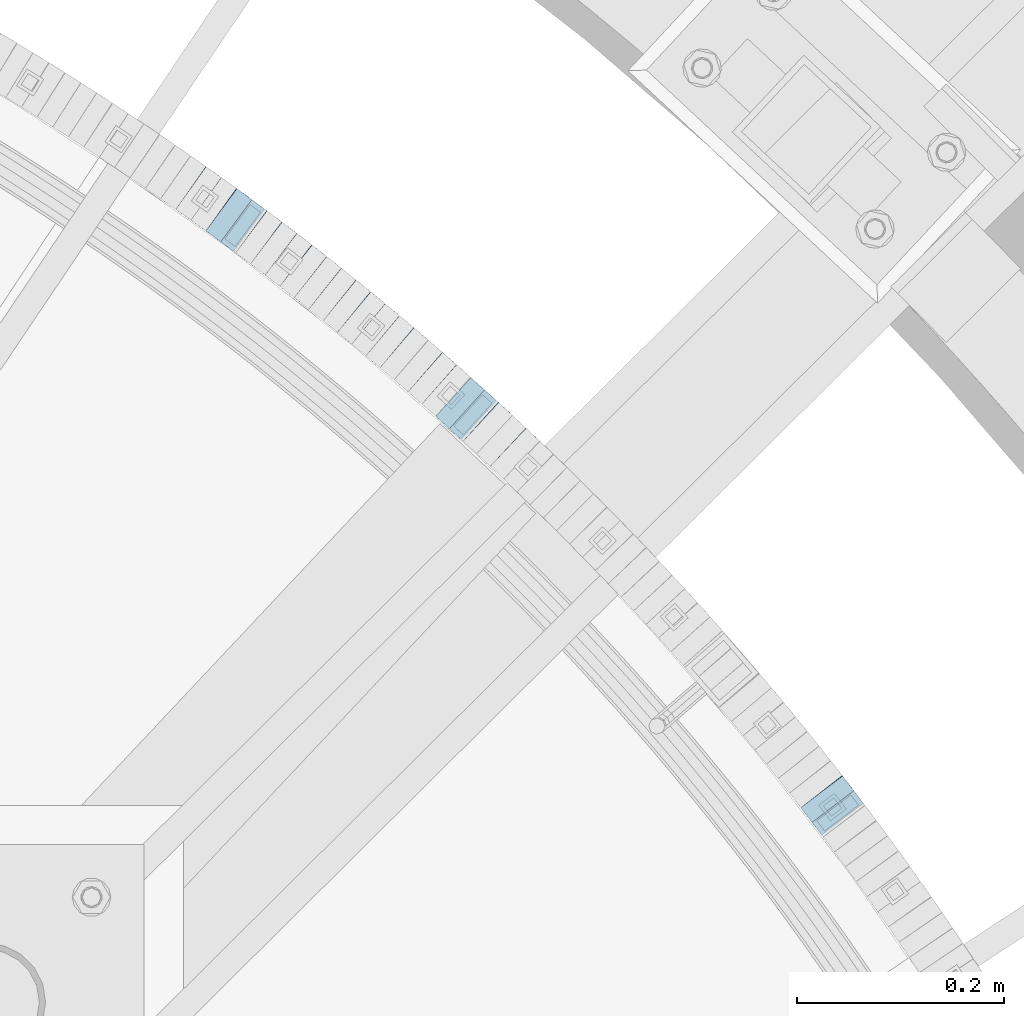
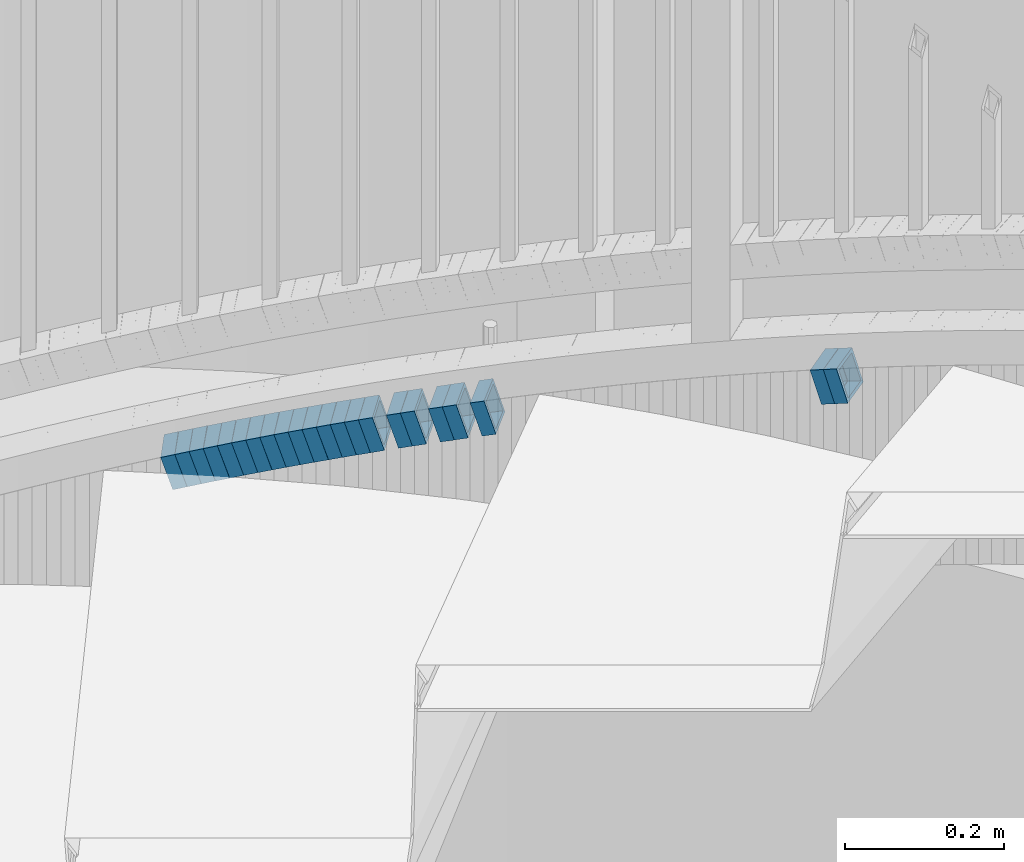
# One storey, part 809 of 975: 22 beams.
"""IFC2X3 building model written with IfcOpenShell, lengths in millimetres."""

from ifc_helpers import new_model, si_unit, frame, origin_with_axes, place, context, subcontext, project, spatial, faceted_brep, material, type_object, element, save


model = new_model("IFC2X3")

# Units and contexts
model_context = context("Model", 3, precision=1e-05, world=origin_with_axes())
body_context = subcontext(model_context, "Body", "Model", "MODEL_VIEW")
ifc_project = project(units=[si_unit("LENGTHUNIT", "METRE", prefix="MILLI"), si_unit("AREAUNIT", "SQUARE_METRE"), si_unit("VOLUMEUNIT", "CUBIC_METRE"), si_unit("MASSUNIT", "GRAM", prefix="KILO"), si_unit("TIMEUNIT", "SECOND"), si_unit("PLANEANGLEUNIT", "RADIAN"), si_unit("SOLIDANGLEUNIT", "STERADIAN"), si_unit("THERMODYNAMICTEMPERATUREUNIT", "DEGREE_CELSIUS"), si_unit("LUMINOUSINTENSITYUNIT", "LUMEN")], contexts=[model_context])

# Site, building, storey
site_placement = place(None, origin_with_axes())
site = spatial("IfcSite", under=ifc_project, at=site_placement, CompositionType="ELEMENT")
building_placement = place(site_placement, origin_with_axes())
building = spatial("IfcBuilding", under=site, at=building_placement, Name="Undefined", CompositionType="ELEMENT")
storey_placement = place(building_placement, origin_with_axes())
storey = spatial("IfcBuildingStorey", under=building, at=storey_placement, Name="Undefined", CompositionType="ELEMENT", Elevation=0.0)

# Beams
ifc_material = material()
beam_type = type_object("IfcBeamType", Name="HSS2X2X.188_TUBES", PredefinedType="NOTDEFINED")
beam_1_placement = place(storey_placement, frame((37018.9722779682, 5141.88097021763, 1879.90491402476), z_axis=(-0.795946119280133, -0.605367471213061, 0.0), x_axis=(-0.576650315926489, 0.758188377903604, -0.304343221961295)))
element("IfcBeam", 1, at=beam_1_placement, inside=storey, type_object=beam_type, material=ifc_material, Name="WALL", ObjectType="HSS2X2X.188_TUBES", context=body_context, shape_type="Brep", body=[
    faceted_brep([(0.0, 20.6374999999753, -20.6375000000298), (0.0, -20.6375000000153, -20.6375000000153), (18.7347271129966, -20.6375000000116, -20.6375000000262), (18.7347271130257, 20.6374999999989, -20.6374999999935), (0.0, -20.6374999999825, 20.6375000000335), (18.7347271129947, -20.6375000000116, 20.6374999999607), (0.0, 20.6375000000116, 20.6375000000189), (18.7347271130147, 20.6375000000007, 20.6374999999898), (0.0, 25.3999999999724, -25.4000000000342), (0.0, 25.400000000016, 25.4000000000196), (18.7347271130166, 25.4000000000015, 25.3999999999905), (18.7347271130257, 25.3999999999996, -25.3999999999869), (0.0, -25.399999999976, 25.4000000000378), (18.7347271129875, -25.4000000000106, 25.3999999999505), (0.0, -25.400000000016, -25.4000000000196), (18.7347271130002, -25.4000000000124, -25.4000000000233)], [[[0, 1, 2, 3]], [[1, 4, 5, 2]], [[4, 6, 7, 5]], [[6, 0, 3, 7]], [[8, 9, 10, 11]], [[9, 12, 13, 10]], [[12, 14, 15, 13]], [[14, 8, 11, 15]], [[13, 15, 11, 10], [5, 7, 3, 2]], [[14, 12, 9, 8], [6, 4, 1, 0]]]),
])
beam_2_placement = place(storey_placement, frame((37008.0467369631, 5156.39942179471, 1874.19955151367), z_axis=(-0.788448067278478, -0.615101329217254, 0.0), x_axis=(-0.586052285084151, 0.751212474107963, -0.303681639043652)))
element("IfcBeam", 2, at=beam_2_placement, inside=storey, type_object=beam_type, material=ifc_material, Name="WALL", ObjectType="HSS2X2X.188_TUBES", context=body_context, shape_type="Brep", body=[
    faceted_brep([(0.0, 20.6374999999753, -20.6375000000298), (0.0, -20.6375000000153, -20.6375000000153), (18.767258723612, -20.6375000000025, -20.6374999999862), (18.7672587236229, 20.6374999999953, -20.637499999968), (0.0, -20.6374999999825, 20.6375000000335), (18.767258723612, -20.6375000000135, 20.6375000000153), (0.0, 20.6375000000116, 20.6375000000189), (18.7672587236266, 20.6374999999844, 20.6375000000371), (0.0, 25.3999999999724, -25.4000000000342), (0.0, 25.400000000016, 25.4000000000196), (18.7672587236302, 25.3999999999814, 25.4000000000342), (18.7672587236229, 25.399999999996, -25.3999999999687), (0.0, -25.399999999976, 25.4000000000378), (18.7672587236157, -25.4000000000142, 25.400000000016), (0.0, -25.400000000016, -25.4000000000196), (18.767258723612, -25.4000000000015, -25.3999999999905)], [[[0, 1, 2, 3]], [[1, 4, 5, 2]], [[4, 6, 7, 5]], [[6, 0, 3, 7]], [[8, 9, 10, 11]], [[9, 12, 13, 10]], [[12, 14, 15, 13]], [[14, 8, 11, 15]], [[13, 15, 11, 10], [5, 7, 3, 2]], [[14, 12, 9, 8], [6, 4, 1, 0]]]),
])
beam_3_placement = place(storey_placement, frame((36705.6258277415, 5490.49306104337, 1730.79732251167), z_axis=(-0.681521706605876, -0.731797897937001, 7.8165840022848e-11), x_axis=(-0.697301910163801, 0.649395672152596, -0.303406175071292)))
element("IfcBeam", 3, at=beam_3_placement, inside=storey, type_object=beam_type, material=ifc_material, Name="WALL", ObjectType="HSS2X2X.188_TUBES", context=body_context, shape_type="Brep", body=[
    faceted_brep([(0.0, 20.6374999999753, -20.6375000000298), (0.0, -20.6375000000153, -20.6375000000153), (18.7853666454903, -20.6375000000535, -20.6375000000326), (18.785366645363, 20.6374999999862, -20.6375000000044), (0.0, -20.6374999999825, 20.6375000000335), (18.785366645352, -20.6375000000007, 20.6374999999989), (0.0, 20.6375000000116, 20.6375000000189), (18.7853666453102, 20.6375000000025, 20.6374999999753), (0.0, 25.3999999999724, -25.4000000000342), (0.0, 25.400000000016, 25.4000000000196), (18.7853666452065, 25.4000000000451, 25.4000000000351), (18.7853666453739, 25.3999999999833, -25.400000000006), (0.0, -25.399999999976, 25.4000000000378), (18.7853666497213, -25.399999993424, 25.3999999995158), (0.0, -25.400000000016, -25.4000000000196), (18.7853666455194, -25.4000000000633, -25.4000000000406)], [[[0, 1, 2, 3]], [[1, 4, 5, 2]], [[4, 6, 7, 5]], [[6, 0, 3, 7]], [[8, 9, 10, 11]], [[9, 12, 13, 10]], [[12, 14, 15, 13]], [[14, 8, 11, 15]], [[13, 15, 11, 10], [5, 7, 3, 2]], [[14, 12, 9, 8], [6, 4, 1, 0]]]),
])
beam_4_placement = place(storey_placement, frame((36679.2089799023, 5515.256758599, 1719.29579487566), z_axis=(-0.669889474924749, -0.742460834916593, 0.0), x_axis=(-0.707506864029783, 0.638352058026783, -0.303217228012712)))
element("IfcBeam", 4, at=beam_4_placement, inside=storey, type_object=beam_type, material=ifc_material, Name="WALL", ObjectType="HSS2X2X.188_TUBES", context=body_context, shape_type="Brep", body=[
    faceted_brep([(0.0, 20.6374999999753, -20.6375000000298), (0.0, -20.6375000000153, -20.6375000000153), (18.8047866246379, -20.6374999999916, -20.6375000000298), (18.8047866247143, 20.6374999999844, -20.6374999999643), (0.0, -20.6374999999825, 20.6375000000335), (18.8047866247107, -20.6375000000189, 20.6375000000407), (0.0, 20.6375000000116, 20.6375000000189), (18.8047866247907, 20.6374999999589, 20.6375000001026), (0.0, 25.3999999999724, -25.4000000000342), (0.0, 25.400000000016, 25.4000000000196), (18.8047866248016, 25.3999999999542, 25.4000000001142), (18.8047866247143, 25.3999999999851, -25.3999999999651), (0.0, -25.399999999976, 25.4000000000378), (18.8047866247107, -25.4000000000196, 25.4000000000415), (0.0, -25.400000000016, -25.4000000000196), (18.8047866246197, -25.3999999999887, -25.4000000000378)], [[[0, 1, 2, 3]], [[1, 4, 5, 2]], [[4, 6, 7, 5]], [[6, 0, 3, 7]], [[8, 9, 10, 11]], [[9, 12, 13, 10]], [[12, 14, 15, 13]], [[14, 8, 11, 15]], [[13, 15, 11, 10], [5, 7, 3, 2]], [[14, 12, 9, 8], [6, 4, 1, 0]]]),
])
beam_5_placement = place(storey_placement, frame((36665.9817506583, 5527.15175978864, 1713.6050548631), z_axis=(-0.672672794195408, -0.739940073214948, 0.0), x_axis=(-0.704835019237743, 0.64075910821609, -0.30436057710264)))
element("IfcBeam", 5, at=beam_5_placement, inside=storey, type_object=beam_type, material=ifc_material, Name="WALL", ObjectType="HSS2X2X.188_TUBES", context=body_context, shape_type="Brep", body=[
    faceted_brep([(0.0, 20.6374999999753, -20.6375000000298), (0.0, -20.6375000000153, -20.6375000000153), (18.7347271129966, -20.6375000000116, -20.6375000000262), (18.7347271130257, 20.6374999999989, -20.6374999999935), (0.0, -20.6374999999825, 20.6375000000335), (18.7347271129947, -20.6375000000116, 20.6374999999607), (0.0, 20.6375000000116, 20.6375000000189), (18.7347271130147, 20.6375000000007, 20.6374999999898), (0.0, 25.3999999999724, -25.4000000000342), (0.0, 25.400000000016, 25.4000000000196), (18.7347271130166, 25.4000000000015, 25.3999999999905), (18.7347271130257, 25.3999999999996, -25.3999999999869), (0.0, -25.399999999976, 25.4000000000378), (18.7347271129875, -25.4000000000106, 25.3999999999505), (0.0, -25.400000000016, -25.4000000000196), (18.7347271130002, -25.4000000000124, -25.4000000000233)], [[[0, 1, 2, 3]], [[1, 4, 5, 2]], [[4, 6, 7, 5]], [[6, 0, 3, 7]], [[8, 9, 10, 11]], [[9, 12, 13, 10]], [[12, 14, 15, 13]], [[14, 8, 11, 15]], [[13, 15, 11, 10], [5, 7, 3, 2]], [[14, 12, 9, 8], [6, 4, 1, 0]]]),
])
beam_6_placement = place(storey_placement, frame((36639.1591654608, 5551.41499836259, 1702.10308609672), z_axis=(-0.660880368115947, -0.750491265131667, 0.0), x_axis=(-0.714943800930169, 0.629577376938469, -0.304117884970286)))
element("IfcBeam", 6, at=beam_6_placement, inside=storey, type_object=beam_type, material=ifc_material, Name="WALL", ObjectType="HSS2X2X.188_TUBES", context=body_context, shape_type="Brep", body=[
    faceted_brep([(0.0, 20.6374999999753, -20.6375000000298), (0.0, -20.6375000000153, -20.6375000000153), (18.7416648140024, -20.6375000000153, -20.6374999999825), (18.7416648139188, 20.6375000000189, -20.6375000000298), (0.0, -20.6374999999825, 20.6375000000335), (18.7416648140097, -20.6375000000189, 20.6375000000226), (0.0, 20.6375000000116, 20.6375000000189), (18.741664813926, 20.6375000000153, 20.6374999999753), (0.0, 25.3999999999724, -25.4000000000342), (0.0, 25.400000000016, 25.4000000000196), (18.7416648139224, 25.4000000000196, 25.3999999999687), (18.7416648139042, 25.4000000000233, -25.4000000000378), (0.0, -25.399999999976, 25.4000000000378), (18.7416648140133, -25.4000000000215, 25.4000000000269), (0.0, -25.400000000016, -25.4000000000196), (18.7416648140133, -25.4000000000196, -25.399999999976)], [[[0, 1, 2, 3]], [[1, 4, 5, 2]], [[4, 6, 7, 5]], [[6, 0, 3, 7]], [[8, 9, 10, 11]], [[9, 12, 13, 10]], [[12, 14, 15, 13]], [[14, 8, 11, 15]], [[13, 15, 11, 10], [5, 7, 3, 2]], [[14, 12, 9, 8], [6, 4, 1, 0]]]),
])
beam_7_placement = place(storey_placement, frame((36625.6453679786, 5563.39542941093, 1696.4018939116), z_axis=(-0.654930538567606, -0.755689082660022, -2.07903667615028e-10), x_axis=(-0.719930889850509, 0.62394010487058, -0.303970819936955)))
element("IfcBeam", 7, at=beam_7_placement, inside=storey, type_object=beam_type, material=ifc_material, Name="WALL", ObjectType="HSS2X2X.188_TUBES", context=body_context, shape_type="Brep", body=[
    faceted_brep([(0.0, 20.6374999999753, -20.6375000000298), (0.0, -20.6375000000153, -20.6375000000153), (18.7547327359644, -20.6374999999844, -20.6375000000553), (18.7547327359898, 20.6375000000171, -20.6375000000335), (0.0, -20.6374999999825, 20.6375000000335), (18.7547327360044, -20.6374999999953, 20.6374999999898), (0.0, 20.6375000000116, 20.6375000000189), (18.7547327360262, 20.6375000000062, 20.6375000000116), (0.0, 25.3999999999724, -25.4000000000342), (0.0, 25.400000000016, 25.4000000000196), (18.7547327360371, 25.4000000000033, 25.4000000000124), (18.7547327359898, 25.4000000000178, -25.4000000000342), (0.0, -25.399999999976, 25.4000000000378), (18.7547327360044, -25.399999999996, 25.3999999999869), (0.0, -25.400000000016, -25.4000000000196), (18.7547327359498, -25.3999999999814, -25.4000000000597)], [[[0, 1, 2, 3]], [[1, 4, 5, 2]], [[4, 6, 7, 5]], [[6, 0, 3, 7]], [[8, 9, 10, 11]], [[9, 12, 13, 10]], [[12, 14, 15, 13]], [[14, 8, 11, 15]], [[13, 15, 11, 10], [5, 7, 3, 2]], [[14, 12, 9, 8], [6, 4, 1, 0]]]),
])
beam_8_placement = place(storey_placement, frame((36598.3128649188, 5587.05371706168, 1684.89909807429), z_axis=(-0.642929821078935, -0.765925091094037, 0.0), x_axis=(-0.729766851144528, 0.612578014121245, -0.30362562406008)))
element("IfcBeam", 8, at=beam_8_placement, inside=storey, type_object=beam_type, material=ifc_material, Name="WALL", ObjectType="HSS2X2X.188_TUBES", context=body_context, shape_type="Brep", body=[
    faceted_brep([(0.0, 20.6374999999753, -20.6375000000298), (0.0, -20.6375000000153, -20.6375000000153), (18.767258723612, -20.6375000000025, -20.6374999999862), (18.7672587236229, 20.6374999999953, -20.637499999968), (0.0, -20.6374999999825, 20.6375000000335), (18.767258723612, -20.6375000000135, 20.6375000000153), (0.0, 20.6375000000116, 20.6375000000189), (18.7672587236266, 20.6374999999844, 20.6375000000371), (0.0, 25.3999999999724, -25.4000000000342), (0.0, 25.400000000016, 25.4000000000196), (18.7672587236302, 25.3999999999814, 25.4000000000342), (18.7672587236229, 25.399999999996, -25.3999999999687), (0.0, -25.399999999976, 25.4000000000378), (18.7672587236157, -25.4000000000142, 25.400000000016), (0.0, -25.400000000016, -25.4000000000196), (18.767258723612, -25.4000000000015, -25.3999999999905)], [[[0, 1, 2, 3]], [[1, 4, 5, 2]], [[4, 6, 7, 5]], [[6, 0, 3, 7]], [[8, 9, 10, 11]], [[9, 12, 13, 10]], [[12, 14, 15, 13]], [[14, 8, 11, 15]], [[13, 15, 11, 10], [5, 7, 3, 2]], [[14, 12, 9, 8], [6, 4, 1, 0]]]),
])
beam_9_placement = place(storey_placement, frame((36584.5697170186, 5598.63304222345, 1679.20713608552), z_axis=(-0.639632351715919, -0.768680983658606, 0.0), x_axis=(-0.73214938788917, 0.609233796907648, -0.304616897953814)))
element("IfcBeam", 9, at=beam_9_placement, inside=storey, type_object=beam_type, material=ifc_material, Name="WALL", ObjectType="HSS2X2X.188_TUBES", context=body_context, shape_type="Brep", body=[
    faceted_brep([(0.0, 20.6374999999753, -20.6375000000298), (0.0, -20.6375000000153, -20.6375000000153), (18.7112265765609, -20.6375000000062, -20.6374999999862), (18.7112265765645, 20.6374999999898, -20.6374999999789), (0.0, -20.6374999999825, 20.6375000000335), (18.7112265765209, -20.6374999999916, 20.6374999999607), (0.0, 20.6375000000116, 20.6375000000189), (18.7112265765245, 20.6375000000025, 20.6374999999716), (0.0, 25.3999999999724, -25.4000000000342), (0.0, 25.400000000016, 25.4000000000196), (18.7112265765172, 25.4000000000051, 25.3999999999614), (18.7112265765718, 25.3999999999887, -25.3999999999724), (0.0, -25.399999999976, 25.4000000000378), (18.7112265765136, -25.3999999999905, 25.3999999999542), (0.0, -25.400000000016, -25.4000000000196), (18.7112265765682, -25.4000000000069, -25.3999999999796)], [[[0, 1, 2, 3]], [[1, 4, 5, 2]], [[4, 6, 7, 5]], [[6, 0, 3, 7]], [[8, 9, 10, 11]], [[9, 12, 13, 10]], [[12, 14, 15, 13]], [[14, 8, 11, 15]], [[13, 15, 11, 10], [5, 7, 3, 2]], [[14, 12, 9, 8], [6, 4, 1, 0]]]),
])
beam_10_placement = place(storey_placement, frame((36570.794202944, 5610.13149613934, 1673.49749635333), z_axis=(-0.636881447137997, -0.770961751510029, 2.71175849775318e-10), x_axis=(-0.734614354880469, 0.606855336901292, -0.303427667950652)))
element("IfcBeam", 10, at=beam_10_placement, inside=storey, type_object=beam_type, material=ifc_material, Name="WALL", ObjectType="HSS2X2X.188_TUBES", context=body_context, shape_type="Brep", body=[
    faceted_brep([(0.0, 20.6374999999753, -20.6375000000298), (0.0, -20.6375000000153, -20.6375000000153), (18.7853666454903, -20.6375000000535, -20.6375000000326), (18.785366645363, 20.6374999999862, -20.6375000000044), (0.0, -20.6374999999825, 20.6375000000335), (18.785366645352, -20.6375000000007, 20.6374999999989), (0.0, 20.6375000000116, 20.6375000000189), (18.7853666453102, 20.6375000000025, 20.6374999999753), (0.0, 25.3999999999724, -25.4000000000342), (0.0, 25.400000000016, 25.4000000000196), (18.7853666452065, 25.4000000000451, 25.4000000000351), (18.7853666453739, 25.3999999999833, -25.400000000006), (0.0, -25.399999999976, 25.4000000000378), (18.7853666497213, -25.399999993424, 25.3999999995158), (0.0, -25.400000000016, -25.4000000000196), (18.7853666455194, -25.4000000000633, -25.4000000000406)], [[[0, 1, 2, 3]], [[1, 4, 5, 2]], [[4, 6, 7, 5]], [[6, 0, 3, 7]], [[8, 9, 10, 11]], [[9, 12, 13, 10]], [[12, 14, 15, 13]], [[14, 8, 11, 15]], [[13, 15, 11, 10], [5, 7, 3, 2]], [[14, 12, 9, 8], [6, 4, 1, 0]]]),
])
beam_11_placement = place(storey_placement, frame((36557.0003357465, 5621.61386368094, 1667.85324558044), z_axis=(-0.630168888270572, -0.776458094333385, 0.0), x_axis=(-0.738147359632107, 0.599076117701472, -0.310235846845399)))
element("IfcBeam", 11, at=beam_11_placement, inside=storey, type_object=beam_type, material=ifc_material, Name="WALL", ObjectType="HSS2X2X.188_TUBES", context=body_context, shape_type="Brep", body=[
    faceted_brep([(0.0, 20.6374999999753, -20.6375000000298), (0.0, -20.6375000000153, -20.6375000000153), (18.6959888745805, -20.6374999999771, -20.6375000000407), (18.6959888746751, 20.637499999988, -20.6374999999716), (0.0, -20.6374999999825, 20.6375000000335), (18.6959888746969, -20.6375000000135, 20.6375000000371), (0.0, 20.6375000000116, 20.6375000000189), (18.6959888747988, 20.6374999999498, 20.6375000001062), (0.0, 25.3999999999724, -25.4000000000342), (0.0, 25.400000000016, 25.4000000000196), (18.695988874817, 25.3999999999414, 25.4000000001215), (18.6959888746678, 25.3999999999887, -25.399999999976), (0.0, -25.399999999976, 25.4000000000378), (18.6959888747042, -25.4000000000124, 25.4000000000378), (0.0, -25.400000000016, -25.4000000000196), (18.695988874555, -25.3999999999687, -25.4000000000597)], [[[0, 1, 2, 3]], [[1, 4, 5, 2]], [[4, 6, 7, 5]], [[6, 0, 3, 7]], [[8, 9, 10, 11]], [[9, 12, 13, 10]], [[12, 14, 15, 13]], [[14, 8, 11, 15]], [[13, 15, 11, 10], [5, 7, 3, 2]], [[14, 12, 9, 8], [6, 4, 1, 0]]]),
])
beam_12_placement = place(storey_placement, frame((36542.9521741602, 5633.08413559692, 1661.9938908066), z_axis=(-0.624695048042231, -0.780868809052785, 0.0), x_axis=(-0.744165184258872, 0.595332147207147, -0.302981539105415)))
element("IfcBeam", 12, at=beam_12_placement, inside=storey, type_object=beam_type, material=ifc_material, Name="WALL", ObjectType="HSS2X2X.188_TUBES", context=body_context, shape_type="Brep", body=[
    faceted_brep([(0.0, 20.6374999999753, -20.6375000000298), (0.0, -20.6375000000153, -20.6375000000153), (18.8066477608099, -20.6374999999862, -20.6375000000116), (18.8066477608172, 20.6375000000062, -20.6374999999971), (0.0, -20.6374999999825, 20.6375000000335), (18.8066477608463, -20.6375000000062, 20.6375000000407), (0.0, 20.6375000000116, 20.6375000000189), (18.8066477608536, 20.6374999999844, 20.637500000048), (0.0, 25.3999999999724, -25.4000000000342), (0.0, 25.400000000016, 25.4000000000196), (18.8066477608591, 25.3999999999814, 25.400000000056), (18.8066477608154, 25.4000000000051, -25.4000000000015), (0.0, -25.399999999976, 25.4000000000378), (18.8066477608518, -25.4000000000087, 25.4000000000451), (0.0, -25.400000000016, -25.4000000000196), (18.8066477608081, -25.3999999999851, -25.4000000000196)], [[[0, 1, 2, 3]], [[1, 4, 5, 2]], [[4, 6, 7, 5]], [[6, 0, 3, 7]], [[8, 9, 10, 11]], [[9, 12, 13, 10]], [[12, 14, 15, 13]], [[14, 8, 11, 15]], [[13, 15, 11, 10], [5, 7, 3, 2]], [[14, 12, 9, 8], [6, 4, 1, 0]]]),
])
beam_13_placement = place(storey_placement, frame((36528.9053779973, 5644.3644718393, 1656.30164875482), z_axis=(-0.621276225268936, -0.783591635940292, -7.90664671512787e-11), x_axis=(-0.746520694737925, 0.59188426479235, -0.303940568893369)))
element("IfcBeam", 13, at=beam_13_placement, inside=storey, type_object=beam_type, material=ifc_material, Name="WALL", ObjectType="HSS2X2X.188_TUBES", context=body_context, shape_type="Brep", body=[
    faceted_brep([(0.0, 20.6374999999753, -20.6375000000298), (0.0, -20.6375000000153, -20.6375000000153), (18.7547327359644, -20.6374999999844, -20.6375000000553), (18.7547327359898, 20.6375000000171, -20.6375000000335), (0.0, -20.6374999999825, 20.6375000000335), (18.7547327360044, -20.6374999999953, 20.6374999999898), (0.0, 20.6375000000116, 20.6375000000189), (18.7547327360262, 20.6375000000062, 20.6375000000116), (0.0, 25.3999999999724, -25.4000000000342), (0.0, 25.400000000016, 25.4000000000196), (18.7547327360371, 25.4000000000033, 25.4000000000124), (18.7547327359898, 25.4000000000178, -25.4000000000342), (0.0, -25.399999999976, 25.4000000000378), (18.7547327360044, -25.399999999996, 25.3999999999869), (0.0, -25.400000000016, -25.4000000000196), (18.7547327359498, -25.3999999999814, -25.4000000000597)], [[[0, 1, 2, 3]], [[1, 4, 5, 2]], [[4, 6, 7, 5]], [[6, 0, 3, 7]], [[8, 9, 10, 11]], [[9, 12, 13, 10]], [[12, 14, 15, 13]], [[14, 8, 11, 15]], [[13, 15, 11, 10], [5, 7, 3, 2]], [[14, 12, 9, 8], [6, 4, 1, 0]]]),
])
beam_14_placement = place(storey_placement, frame((36514.8578426775, 5655.54534385093, 1650.60943730135), z_axis=(-0.61782155188774, -0.786318338857122, 0.0), x_axis=(-0.74887728675883, 0.588403582810485, -0.304900037901799)))
element("IfcBeam", 14, at=beam_14_placement, inside=storey, type_object=beam_type, material=ifc_material, Name="WALL", ObjectType="HSS2X2X.188_TUBES", context=body_context, shape_type="Brep", body=[
    faceted_brep([(0.0, 20.6374999999753, -20.6375000000298), (0.0, -20.6375000000153, -20.6375000000153), (18.6895692834223, -20.637499999988, -20.6374999999862), (18.6895692834369, 20.6374999999953, -20.6374999999534), (0.0, -20.6374999999825, 20.6375000000335), (18.6895692833914, -20.637499999988, 20.6374999999789), (0.0, 20.6375000000116, 20.6375000000189), (18.6895692834078, 20.6374999999953, 20.637500000008), (0.0, 25.3999999999724, -25.4000000000342), (0.0, 25.400000000016, 25.4000000000196), (18.6895692834059, 25.3999999999924, 25.4000000000087), (18.6895692834423, 25.3999999999942, -25.3999999999432), (0.0, -25.399999999976, 25.4000000000378), (18.6895692833878, -25.3999999999869, 25.3999999999687), (0.0, -25.400000000016, -25.4000000000196), (18.6895692834241, -25.3999999999869, -25.3999999999833)], [[[0, 1, 2, 3]], [[1, 4, 5, 2]], [[4, 6, 7, 5]], [[6, 0, 3, 7]], [[8, 9, 10, 11]], [[9, 12, 13, 10]], [[12, 14, 15, 13]], [[14, 8, 11, 15]], [[13, 15, 11, 10], [5, 7, 3, 2]], [[14, 12, 9, 8], [6, 4, 1, 0]]]),
])
beam_15_placement = place(storey_placement, frame((36500.7519445464, 5666.73894916533, 1644.93665674053), z_axis=(-0.60890054125397, -0.793246576330855, 0.0), x_axis=(-0.754625564178323, 0.579254834136788, -0.308227343072788)))
element("IfcBeam", 15, at=beam_15_placement, inside=storey, type_object=beam_type, material=ifc_material, Name="WALL", ObjectType="HSS2X2X.188_TUBES", context=body_context, shape_type="Brep", body=[
    faceted_brep([(0.0, 20.6374999999753, -20.6375000000298), (0.0, -20.6375000000153, -20.6375000000153), (18.8225928075335, -20.6374999999935, -20.6375000000298), (18.8225928075699, 20.6374999999898, -20.6374999999825), (0.0, -20.6374999999825, 20.6375000000335), (18.8225928075772, -20.637500000008, 20.6375000000226), (0.0, 20.6375000000116, 20.6375000000189), (18.8225928076135, 20.6374999999753, 20.6375000000698), (0.0, 25.3999999999724, -25.4000000000342), (0.0, 25.400000000016, 25.4000000000196), (18.8225928076281, 25.3999999999705, 25.4000000000815), (18.8225928075663, 25.3999999999905, -25.3999999999796), (0.0, -25.399999999976, 25.4000000000378), (18.8225928075808, -25.4000000000087, 25.4000000000233), (0.0, -25.400000000016, -25.4000000000196), (18.8225928075226, -25.3999999999905, -25.4000000000378)], [[[0, 1, 2, 3]], [[1, 4, 5, 2]], [[4, 6, 7, 5]], [[6, 0, 3, 7]], [[8, 9, 10, 11]], [[9, 12, 13, 10]], [[12, 14, 15, 13]], [[14, 8, 11, 15]], [[13, 15, 11, 10], [5, 7, 3, 2]], [[14, 12, 9, 8], [6, 4, 1, 0]]]),
])
beam_16_placement = place(storey_placement, frame((36486.4048138269, 5677.79490140976, 1639.10491402254), z_axis=(-0.605367471213059, -0.795946119280134, 0.0), x_axis=(-0.758188377903574, 0.576650315926565, -0.304343221961227)))
element("IfcBeam", 16, at=beam_16_placement, inside=storey, type_object=beam_type, material=ifc_material, Name="WALL", ObjectType="HSS2X2X.188_TUBES", context=body_context, shape_type="Brep", body=[
    faceted_brep([(0.0, 20.6374999999753, -20.6375000000298), (0.0, -20.6375000000153, -20.6375000000153), (18.7347271129966, -20.6375000000116, -20.6375000000262), (18.7347271130257, 20.6374999999989, -20.6374999999935), (0.0, -20.6374999999825, 20.6375000000335), (18.7347271129947, -20.6375000000116, 20.6374999999607), (0.0, 20.6375000000116, 20.6375000000189), (18.7347271130147, 20.6375000000007, 20.6374999999898), (0.0, 25.3999999999724, -25.4000000000342), (0.0, 25.400000000016, 25.4000000000196), (18.7347271130166, 25.4000000000015, 25.3999999999905), (18.7347271130257, 25.3999999999996, -25.3999999999869), (0.0, -25.399999999976, 25.4000000000378), (18.7347271129875, -25.4000000000106, 25.3999999999505), (0.0, -25.400000000016, -25.4000000000196), (18.7347271130002, -25.4000000000124, -25.4000000000233)], [[[0, 1, 2, 3]], [[1, 4, 5, 2]], [[4, 6, 7, 5]], [[6, 0, 3, 7]], [[8, 9, 10, 11]], [[9, 12, 13, 10]], [[12, 14, 15, 13]], [[14, 8, 11, 15]], [[13, 15, 11, 10], [5, 7, 3, 2]], [[14, 12, 9, 8], [6, 4, 1, 0]]]),
])
beam_17_placement = place(storey_placement, frame((36472.0760769791, 5688.76795790476, 1633.40245464473), z_axis=(-0.59910376812092, -0.800671390161603, 0.0), x_axis=(-0.762767019599611, 0.57074175570048, -0.304040000840451)))
element("IfcBeam", 17, at=beam_17_placement, inside=storey, type_object=beam_type, material=ifc_material, Name="WALL", ObjectType="HSS2X2X.188_TUBES", context=body_context, shape_type="Brep", body=[
    faceted_brep([(0.0, 20.6374999999753, -20.6375000000298), (0.0, -20.6375000000153, -20.6375000000153), (18.7547327359644, -20.6374999999844, -20.6375000000553), (18.7547327359898, 20.6375000000171, -20.6375000000335), (0.0, -20.6374999999825, 20.6375000000335), (18.7547327360044, -20.6374999999953, 20.6374999999898), (0.0, 20.6375000000116, 20.6375000000189), (18.7547327360262, 20.6375000000062, 20.6375000000116), (0.0, 25.3999999999724, -25.4000000000342), (0.0, 25.400000000016, 25.4000000000196), (18.7547327360371, 25.4000000000033, 25.4000000000124), (18.7547327359898, 25.4000000000178, -25.4000000000342), (0.0, -25.399999999976, 25.4000000000378), (18.7547327360044, -25.399999999996, 25.3999999999869), (0.0, -25.400000000016, -25.4000000000196), (18.7547327359498, -25.3999999999814, -25.4000000000597)], [[[0, 1, 2, 3]], [[1, 4, 5, 2]], [[4, 6, 7, 5]], [[6, 0, 3, 7]], [[8, 9, 10, 11]], [[9, 12, 13, 10]], [[12, 14, 15, 13]], [[14, 8, 11, 15]], [[13, 15, 11, 10], [5, 7, 3, 2]], [[14, 12, 9, 8], [6, 4, 1, 0]]]),
])
beam_18_placement = place(storey_placement, frame((36457.7445974865, 5699.56716569031, 1627.73927704491), z_axis=(-0.592817428097412, -0.80533688413233, 0.0), x_axis=(-0.766044147642035, 0.563893608736405, -0.308545558855775)))
element("IfcBeam", 18, at=beam_18_placement, inside=storey, type_object=beam_type, material=ifc_material, Name="WALL", ObjectType="HSS2X2X.188_TUBES", context=body_context, shape_type="Brep", body=[
    faceted_brep([(0.0, 20.6374999999753, -20.6375000000298), (0.0, -20.6375000000153, -20.6375000000153), (18.8047866246379, -20.6374999999916, -20.6375000000298), (18.8047866247143, 20.6374999999844, -20.6374999999643), (0.0, -20.6374999999825, 20.6375000000335), (18.8047866247107, -20.6375000000189, 20.6375000000407), (0.0, 20.6375000000116, 20.6375000000189), (18.8047866247907, 20.6374999999589, 20.6375000001026), (0.0, 25.3999999999724, -25.4000000000342), (0.0, 25.400000000016, 25.4000000000196), (18.8047866248016, 25.3999999999542, 25.4000000001142), (18.8047866247143, 25.3999999999851, -25.3999999999651), (0.0, -25.399999999976, 25.4000000000378), (18.8047866247107, -25.4000000000196, 25.4000000000415), (0.0, -25.400000000016, -25.4000000000196), (18.8047866246197, -25.3999999999887, -25.4000000000378)], [[[0, 1, 2, 3]], [[1, 4, 5, 2]], [[4, 6, 7, 5]], [[6, 0, 3, 7]], [[8, 9, 10, 11]], [[9, 12, 13, 10]], [[12, 14, 15, 13]], [[14, 8, 11, 15]], [[13, 15, 11, 10], [5, 7, 3, 2]], [[14, 12, 9, 8], [6, 4, 1, 0]]]),
])
beam_19_placement = place(storey_placement, frame((36443.2458968979, 5710.23982029034, 1621.89986563076), z_axis=(-0.592817428097412, -0.80533688413233, 0.0), x_axis=(-0.767293732919849, 0.564813441940945, -0.303720435968254)))
element("IfcBeam", 19, at=beam_19_placement, inside=storey, type_object=beam_type, material=ifc_material, Name="WALL", ObjectType="HSS2X2X.188_TUBES", context=body_context, shape_type="Brep", body=[
    faceted_brep([(0.0, 20.6374999999753, -20.6375000000298), (0.0, -20.6375000000153, -20.6375000000153), (18.767258723612, -20.6375000000025, -20.6374999999862), (18.7672587236229, 20.6374999999953, -20.637499999968), (0.0, -20.6374999999825, 20.6375000000335), (18.767258723612, -20.6375000000135, 20.6375000000153), (0.0, 20.6375000000116, 20.6375000000189), (18.7672587236266, 20.6374999999844, 20.6375000000371), (0.0, 25.3999999999724, -25.4000000000342), (0.0, 25.400000000016, 25.4000000000196), (18.7672587236302, 25.3999999999814, 25.4000000000342), (18.7672587236229, 25.399999999996, -25.3999999999687), (0.0, -25.399999999976, 25.4000000000378), (18.7672587236157, -25.4000000000142, 25.400000000016), (0.0, -25.400000000016, -25.4000000000196), (18.767258723612, -25.4000000000015, -25.3999999999905)], [[[0, 1, 2, 3]], [[1, 4, 5, 2]], [[4, 6, 7, 5]], [[6, 0, 3, 7]], [[8, 9, 10, 11]], [[9, 12, 13, 10]], [[12, 14, 15, 13]], [[14, 8, 11, 15]], [[13, 15, 11, 10], [5, 7, 3, 2]], [[14, 12, 9, 8], [6, 4, 1, 0]]]),
])
beam_20_placement = place(storey_placement, frame((36414.1809695448, 5731.50885174718, 1610.53354835644), z_axis=(-0.580182279825393, -0.81448666175488, 0.0), x_axis=(-0.774931202071096, 0.552005788050687, -0.307849382028268)))
element("IfcBeam", 20, at=beam_20_placement, inside=storey, type_object=beam_type, material=ifc_material, Name="WALL", ObjectType="HSS2X2X.188_TUBES", context=body_context, shape_type="Brep", body=[
    faceted_brep([(0.0, 20.6374999999753, -20.6375000000298), (0.0, -20.6375000000153, -20.6375000000153), (18.8433011969464, -20.6374999999898, -20.6375000000226), (18.8433011969719, 20.6375000000007, -20.6374999999862), (0.0, -20.6374999999825, 20.6375000000335), (18.8433011969828, -20.6375000000044, 20.6375000000189), (0.0, 20.6375000000116, 20.6375000000189), (18.8433011970155, 20.6374999999862, 20.6375000000517), (0.0, 25.3999999999724, -25.4000000000342), (0.0, 25.400000000016, 25.4000000000196), (18.8433011970228, 25.3999999999833, 25.4000000000597), (18.8433011969719, 25.4000000000015, -25.3999999999869), (0.0, -25.399999999976, 25.4000000000378), (18.8433011969864, -25.4000000000051, 25.4000000000196), (0.0, -25.400000000016, -25.4000000000196), (18.8433011969391, -25.3999999999869, -25.4000000000269)], [[[0, 1, 2, 3]], [[1, 4, 5, 2]], [[4, 6, 7, 5]], [[6, 0, 3, 7]], [[8, 9, 10, 11]], [[9, 12, 13, 10]], [[12, 14, 15, 13]], [[14, 8, 11, 15]], [[13, 15, 11, 10], [5, 7, 3, 2]], [[14, 12, 9, 8], [6, 4, 1, 0]]]),
])
beam_21_placement = place(storey_placement, frame((36428.6598417878, 5721.09288334556, 1616.20445651993), z_axis=(-0.582827439183259, -0.812595948879321, -7.00351847626733e-11), x_axis=(-0.77406301666602, 0.555190025760555, -0.304286840868767)))
element("IfcBeam", 21, at=beam_21_placement, inside=storey, type_object=beam_type, material=ifc_material, Name="WALL", ObjectType="HSS2X2X.188_TUBES", context=body_context, shape_type="Brep", body=[
    faceted_brep([(0.0, 20.6374999999753, -20.6375000000298), (0.0, -20.6375000000153, -20.6375000000153), (18.7347271129966, -20.6375000000116, -20.6375000000262), (18.7347271130257, 20.6374999999989, -20.6374999999935), (0.0, -20.6374999999825, 20.6375000000335), (18.7347271129947, -20.6375000000116, 20.6374999999607), (0.0, 20.6375000000116, 20.6375000000189), (18.7347271130147, 20.6375000000007, 20.6374999999898), (0.0, 25.3999999999724, -25.4000000000342), (0.0, 25.400000000016, 25.4000000000196), (18.7347271130166, 25.4000000000015, 25.3999999999905), (18.7347271130257, 25.3999999999996, -25.3999999999869), (0.0, -25.399999999976, 25.4000000000378), (18.7347271129875, -25.4000000000106, 25.3999999999505), (0.0, -25.400000000016, -25.4000000000196), (18.7347271130002, -25.4000000000124, -25.4000000000233)], [[[0, 1, 2, 3]], [[1, 4, 5, 2]], [[4, 6, 7, 5]], [[6, 0, 3, 7]], [[8, 9, 10, 11]], [[9, 12, 13, 10]], [[12, 14, 15, 13]], [[14, 8, 11, 15]], [[13, 15, 11, 10], [5, 7, 3, 2]], [[14, 12, 9, 8], [6, 4, 1, 0]]]),
])
beam_22_placement = place(storey_placement, frame((36399.3469980985, 5742.14791381733, 1604.69133852125), z_axis=(-0.573836192044372, -0.818970100003666, -1.08714175439673e-11), x_axis=(-0.780557870904632, 0.546921500933261, -0.302665296963061)))
element("IfcBeam", 22, at=beam_22_placement, inside=storey, type_object=beam_type, material=ifc_material, Name="WALL", ObjectType="HSS2X2X.188_TUBES", context=body_context, shape_type="Brep", body=[
    faceted_brep([(0.0, 20.6374999999753, -20.6375000000298), (0.0, -20.6375000000153, -20.6375000000153), (18.8332159191086, -20.6374999999916, -20.6375000000153), (18.8332159190923, 20.6375000000062, -20.6375000000335), (0.0, -20.6374999999825, 20.6375000000335), (18.8332159191377, -20.6375000000062, 20.6375000000335), (0.0, 20.6375000000116, 20.6375000000189), (18.8332159191141, 20.6374999999916, 20.6375000000116), (0.0, 25.3999999999724, -25.4000000000342), (0.0, 25.400000000016, 25.4000000000196), (18.8332159191159, 25.3999999999905, 25.4000000000124), (18.8332159190886, 25.4000000000069, -25.4000000000415), (0.0, -25.399999999976, 25.4000000000378), (18.8332159191395, -25.4000000000069, 25.4000000000378), (0.0, -25.400000000016, -25.4000000000196), (18.8332159191104, -25.3999999999905, -25.400000000016)], [[[0, 1, 2, 3]], [[1, 4, 5, 2]], [[4, 6, 7, 5]], [[6, 0, 3, 7]], [[8, 9, 10, 11]], [[9, 12, 13, 10]], [[12, 14, 15, 13]], [[14, 8, 11, 15]], [[13, 15, 11, 10], [5, 7, 3, 2]], [[14, 12, 9, 8], [6, 4, 1, 0]]]),
])

save(model, "model.ifc")
